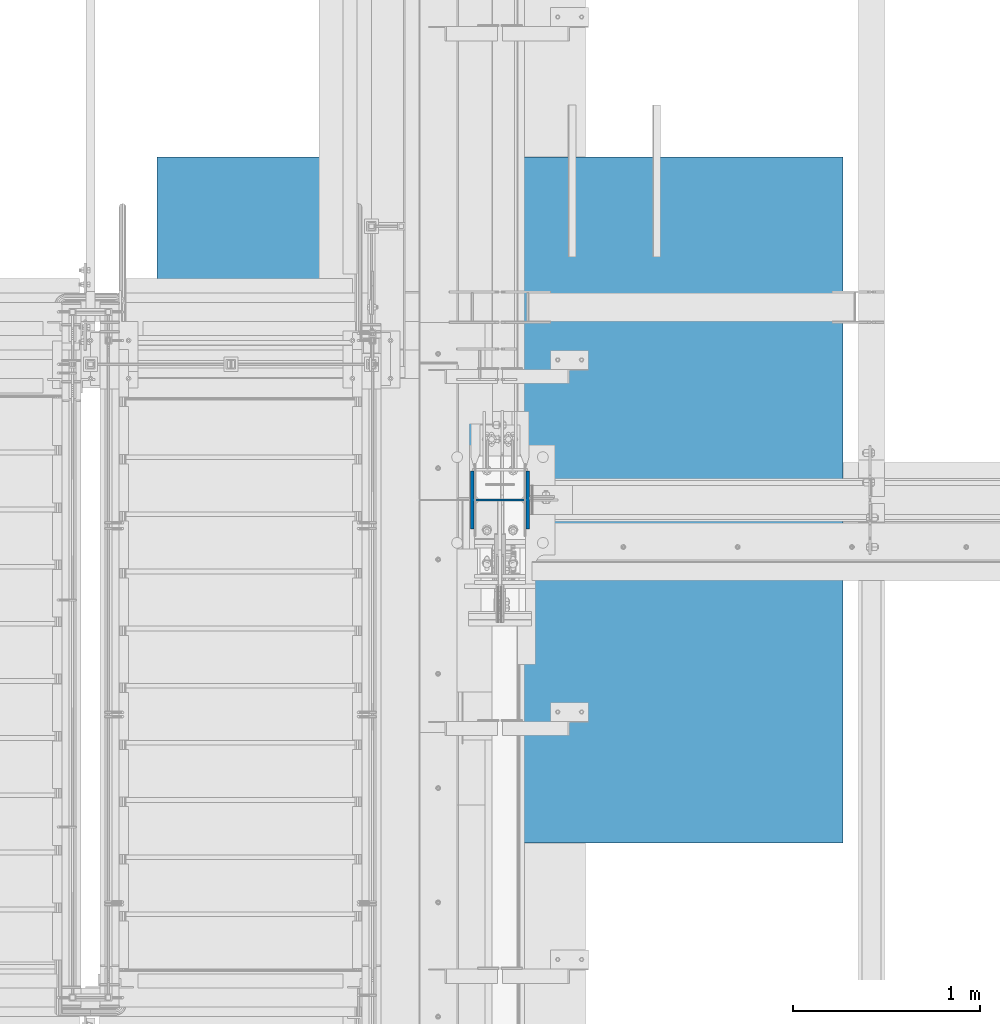
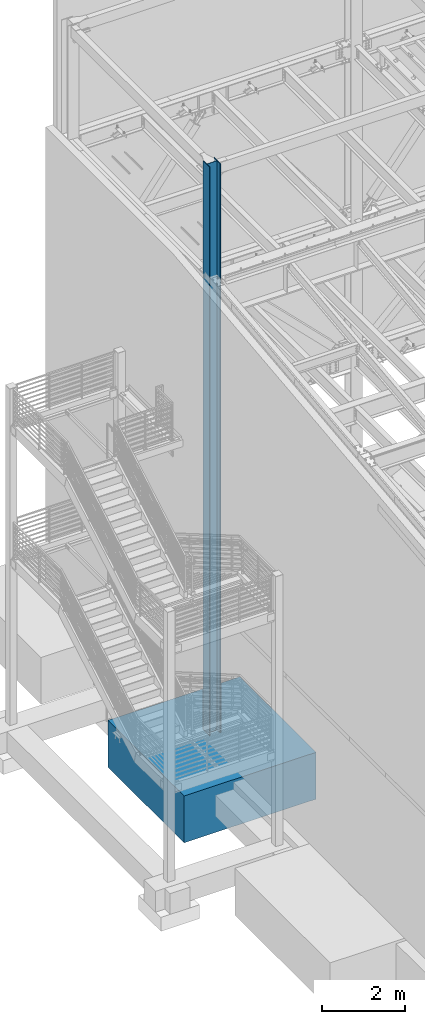
# One storey, part 363 of 1179: 2 columns, 2 elements without a shape of their own.
"""IFC2X3 building model written with IfcOpenShell, lengths in millimetres."""

from ifc_helpers import new_model, si_unit, frame, origin_with_axes, place, context, subcontext, project, spatial, faceted_brep, material, type_object, element, aggregate, save


model = new_model("IFC2X3")

# Units and contexts
model_context = context("Model", 3, precision=1e-05, world=origin_with_axes())
body_context = subcontext(model_context, "Body", "Model", "MODEL_VIEW")
ifc_project = project(units=[si_unit("LENGTHUNIT", "METRE", prefix="MILLI"), si_unit("AREAUNIT", "SQUARE_METRE"), si_unit("VOLUMEUNIT", "CUBIC_METRE"), si_unit("MASSUNIT", "GRAM", prefix="KILO"), si_unit("TIMEUNIT", "SECOND"), si_unit("PLANEANGLEUNIT", "RADIAN"), si_unit("SOLIDANGLEUNIT", "STERADIAN"), si_unit("THERMODYNAMICTEMPERATUREUNIT", "DEGREE_CELSIUS"), si_unit("LUMINOUSINTENSITYUNIT", "LUMEN")], contexts=[model_context])

# Site, building, storey
site_placement = place(None, origin_with_axes())
site = spatial("IfcSite", under=ifc_project, at=site_placement, CompositionType="ELEMENT")
building_placement = place(site_placement, origin_with_axes())
building = spatial("IfcBuilding", under=site, at=building_placement, Name="Undefined", CompositionType="ELEMENT")
storey_placement = place(building_placement, origin_with_axes())
storey = spatial("IfcBuildingStorey", under=building, at=storey_placement, Name="Undefined", CompositionType="ELEMENT", Elevation=0.0)

# Assembly, column
assembly_1_placement = place(storey_placement, origin_with_axes())
assembly_1 = element("IfcElementAssembly", 1, at=assembly_1_placement, inside=storey, Name="FOOTING", AssemblyPlace="NOTDEFINED", PredefinedType="REINFORCEMENT_UNIT")
ifc_material_1 = material(Name="CONCRETE/3000")
column_type_1 = type_object("IfcColumnType", PredefinedType="NOTDEFINED")
column_1_placement = place(assembly_1_placement, frame((431.8, 34391.6, -1727.2), z_axis=(-1.0, 0.0, 0.0), x_axis=(0.0, 0.0, 1.0)))
column_1 = element("IfcColumn", 2, at=column_1_placement, type_object=column_type_1, material=ifc_material_1, Name="FOOTING", context=body_context, shape_type="Brep", body=[
    faceted_brep([(0.0, 1828.8, -1828.8), (0.0, 1828.8, 1828.8), (1371.6, 1828.8, 1828.8), (1371.6, 1828.8, -1828.8), (0.0, -1828.8, 1828.8), (1371.6, -1828.8, 1828.8), (0.0, -1828.8, -1828.8), (1371.6, -1828.8, -1828.8)], [[[0, 1, 2, 3]], [[1, 4, 5, 2]], [[4, 6, 7, 5]], [[6, 0, 3, 7]], [[5, 7, 3, 2]], [[6, 4, 1, 0]]]),
])
aggregate(assembly_1, [column_1])

assembly_2_placement = place(storey_placement, origin_with_axes())
assembly_2 = element("IfcElementAssembly", 3, at=assembly_2_placement, inside=storey, Name="COLUMN", AssemblyPlace="NOTDEFINED", PredefinedType="RIGID_FRAME")
ifc_material_2 = material(Name="STEEL/A992")
column_type_2 = type_object("IfcColumnType", Name="W12X79", PredefinedType="NOTDEFINED")
column_2_placement = place(assembly_2_placement, frame((431.8, 34391.6, -355.6), z_axis=(-1.0, 0.0, 0.0), x_axis=(0.0, 0.0, 1.0)))
column_2 = element("IfcColumn", 4, at=column_2_placement, type_object=column_type_2, material=ifc_material_2, Name="COLUMN", ObjectType="W12X79", context=body_context, shape_type="Brep", body=[
    faceted_brep([(160.223581529497, -153.987499999999, 157.1625), (160.223581529497, 153.987499999999, 157.1625), (149.225002356772, 153.987499999999, 138.1125), (149.225002356772, 6.35000012494493, 138.1125), (148.995793121516, 6.35000012313685, 137.715499999996), (148.995793121516, -6.34999999999854, 137.715499999996), (149.225002356772, -6.34999999999854, 138.1125), (149.225002356772, -153.987499999999, 138.1125), (16814.8, 153.987500000003, -157.1625), (16814.8, -153.987500000003, -157.1625), (160.223597538519, -153.987499999999, -157.1625), (160.223597538519, 153.987499999999, -157.1625), (16814.8, -153.987500000003, -138.1125), (149.225402461476, -153.987499999999, -138.1125), (16814.8, -6.34999999999854, -138.1125), (149.225402461476, -6.34999999999854, -138.1125), (188.913, -6.34999999999854, 137.715499999996), (188.913, 6.35000008947463, 137.715499999996), (208.49066058208, 6.35000008789211, 131.2871410688), (208.49066058208, -6.34999999999854, 131.2871410688), (212.873373738864, 6.35000008718271, 128.290736246858), (212.873373738864, -6.34999999999854, 128.290736246858), (214.971292158606, 6.35000008606585, 123.413713099926), (214.971292158606, -6.34999999999854, 123.413713099926), (214.132634973196, 6.3500000848835, 118.171264187733), (214.132634973196, -6.34999999999854, 118.171264187733), (210.617956026487, 6.35000008400311, 114.192112472459), (210.617956026487, -6.34999999999854, 114.192112472459), (205.519195059062, 6.35000008370116, 112.712499999996), (205.519195059062, -6.34999999999854, 112.712499999996), (147.032344061553, 6.35000011347802, 112.712499999996), (139.700000000001, -6.34999999999854, 112.712499999996), (147.032344061555, 6.35000001149092, -112.712500000003), (139.700000000001, -6.34999999999854, -112.712500000003), (205.519195059063, 6.3500000365857, -112.712500000003), (205.519195059063, -6.34999999999854, -112.712500000003), (210.617956026486, 6.35000003621826, -114.192112472468), (210.617956026486, -6.34999999999854, -114.192112472468), (214.132634973195, 6.35000003529422, -118.171264187741), (214.132634973195, -6.34999999999854, -118.171264187741), (214.971292158605, 6.35000003410096, -123.413713099934), (214.971292158605, -6.34999999999854, -123.413713099934), (212.873373738863, 6.35000003300956, -128.290736246865), (212.873373738863, -6.34999999999854, -128.290736246865), (208.49066058208, 6.35000003235837, -131.287141068808), (208.49066058208, -6.34999999999854, -131.287141068808), (188.913, 6.35000003102323, -137.715500000003), (188.913, -6.34999999999854, -137.715500000003), (148.99620123074, 6.35000000162472, -137.715500000003), (148.99620123074, -6.34999999999854, -137.715500000003), (16814.8, 6.34999999999854, -138.1125), (16814.8, 153.987500000003, -138.1125), (149.225402461476, 153.987499999999, -138.1125), (149.225402461477, 6.34999999999854, -138.1125), (16814.8, 6.34999999999854, 138.1125), (16814.8, 153.987500000003, 138.1125), (16814.8, 153.987500000003, 157.1625), (16814.8, -153.987500000003, 157.1625), (16814.8, -153.987500000003, 138.1125), (16814.8, -6.34999999999854, 138.1125)], [[[0, 1, 2, 3, 4, 5, 6, 7]], [[8, 9, 10, 11]], [[9, 12, 13, 10]], [[12, 14, 15, 13]], [[16, 17, 18, 19]], [[19, 18, 20, 21]], [[21, 20, 22, 23]], [[23, 22, 24, 25]], [[25, 24, 26, 27]], [[27, 26, 28, 29]], [[29, 28, 30, 31]], [[32, 33, 31, 30]], [[33, 32, 34, 35]], [[35, 34, 36, 37]], [[37, 36, 38, 39]], [[39, 38, 40, 41]], [[41, 40, 42, 43]], [[43, 42, 44, 45]], [[45, 44, 46, 47]], [[47, 46, 48, 49]], [[50, 51, 52, 53]], [[10, 13, 15, 49, 48, 53, 52, 11]], [[51, 8, 11, 52]], [[50, 54, 55, 56, 57, 58, 59, 14, 12, 9, 8, 51]], [[58, 57, 0, 7]], [[59, 58, 7, 6]], [[16, 19, 21, 23, 25, 27, 29, 31, 33, 35, 37, 39, 41, 43, 45, 47, 49, 15, 14, 59, 6, 5]], [[17, 16, 5, 4]], [[54, 50, 53, 48, 46, 44, 42, 40, 38, 36, 34, 32, 30, 28, 26, 24, 22, 20, 18, 17, 4, 3]], [[55, 54, 3, 2]], [[56, 55, 2, 1]], [[57, 56, 1, 0]]]),
])
aggregate(assembly_2, [column_2])

save(model, "model.ifc")
